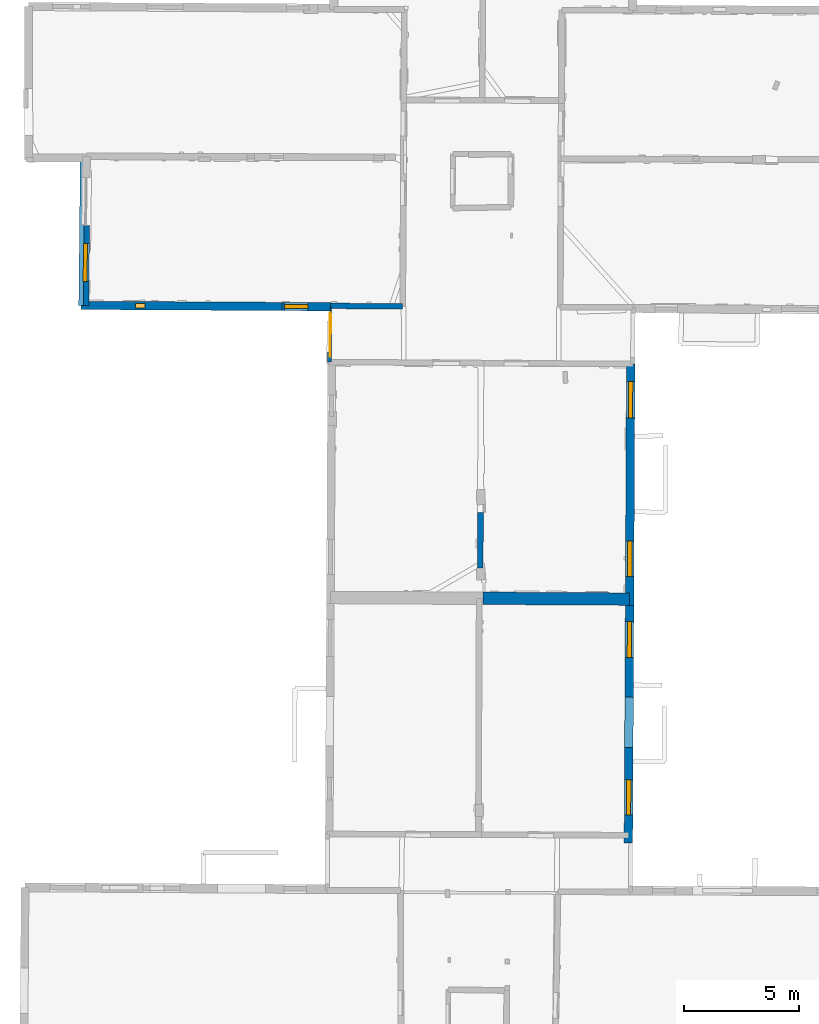
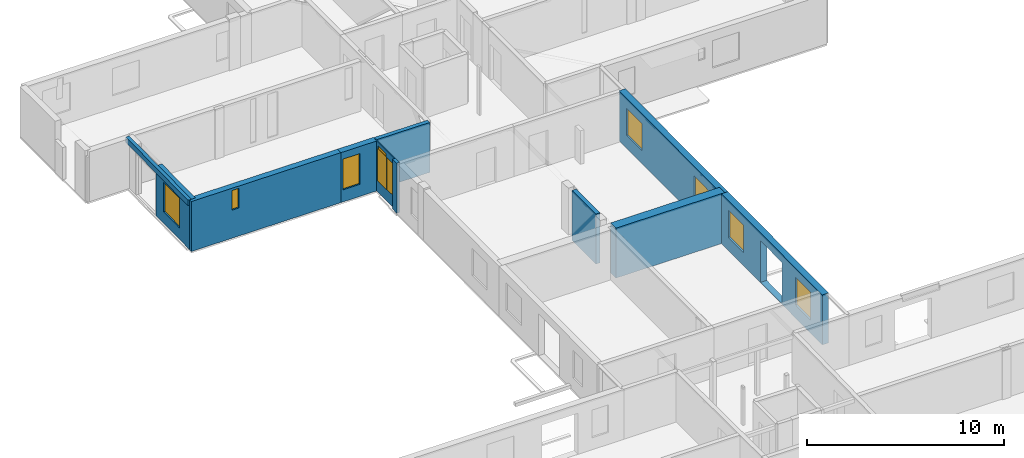
# One storey, part 8 of 17: 11 walls, 8 windows, 2 doors, 11 openings.
"""IFC2X3 building model written with IfcOpenShell, lengths in metres."""

from ifc_helpers import new_model, entity, si_unit, converted_unit, derived_unit, direction, frame, frame_2d, origin, origin_2d_with_axis, place, context, subcontext, project, spatial, polyline, rectangle, outline, extrude, clip, halfspace, source, transform, mapped, material, layer, layer_set, layer_usage, type_object, type_shapes, element, fill, save


model = new_model("IFC2X3")

# Units and contexts
model_context = context("Model", 3, precision=1e-05, world=origin(), true_north=direction((0.0, 1.0)))
body_context = subcontext(model_context, "Body", "Model", "MODEL_VIEW")
ifc_project = project(units=[si_unit("LENGTHUNIT", "METRE"), si_unit("AREAUNIT", "SQUARE_METRE"), si_unit("VOLUMEUNIT", "CUBIC_METRE"), converted_unit("PLANEANGLEUNIT", "DEGREE", entity("IfcRatioMeasure", 0.0174532925199433), si_unit("PLANEANGLEUNIT", "RADIAN"), dimensions=[0, 0, 0, 0, 0, 0, 0]), si_unit("MASSUNIT", "GRAM", prefix="KILO"), derived_unit("MASSDENSITYUNIT", [(si_unit("MASSUNIT", "GRAM", prefix="KILO"), 1), (si_unit("LENGTHUNIT", "METRE"), -3)]), derived_unit("MOMENTOFINERTIAUNIT", [(si_unit("LENGTHUNIT", "METRE"), 4)]), si_unit("TIMEUNIT", "SECOND"), si_unit("FREQUENCYUNIT", "HERTZ"), si_unit("THERMODYNAMICTEMPERATUREUNIT", "DEGREE_CELSIUS"), derived_unit("THERMALTRANSMITTANCEUNIT", [(si_unit("MASSUNIT", "GRAM", prefix="KILO"), 1), (si_unit("THERMODYNAMICTEMPERATUREUNIT", "KELVIN"), -1), (si_unit("TIMEUNIT", "SECOND"), -3)]), derived_unit("VOLUMETRICFLOWRATEUNIT", [(si_unit("LENGTHUNIT", "METRE"), 3), (si_unit("TIMEUNIT", "SECOND"), -1)]), si_unit("ELECTRICCURRENTUNIT", "AMPERE"), si_unit("ELECTRICVOLTAGEUNIT", "VOLT"), si_unit("POWERUNIT", "WATT"), si_unit("FORCEUNIT", "NEWTON", prefix="KILO"), si_unit("ILLUMINANCEUNIT", "LUX"), si_unit("LUMINOUSFLUXUNIT", "LUMEN"), si_unit("LUMINOUSINTENSITYUNIT", "CANDELA"), derived_unit("USERDEFINED", [(si_unit("MASSUNIT", "GRAM", prefix="KILO"), -1), (si_unit("LENGTHUNIT", "METRE"), -2), (si_unit("TIMEUNIT", "SECOND"), 3), (si_unit("LUMINOUSFLUXUNIT", "LUMEN"), 1)]), derived_unit("LINEARVELOCITYUNIT", [(si_unit("LENGTHUNIT", "METRE"), 1), (si_unit("TIMEUNIT", "SECOND"), -1)]), si_unit("PRESSUREUNIT", "PASCAL"), derived_unit("USERDEFINED", [(si_unit("LENGTHUNIT", "METRE"), -2), (si_unit("MASSUNIT", "GRAM", prefix="KILO"), 1), (si_unit("TIMEUNIT", "SECOND"), -2)]), derived_unit("LINEARFORCEUNIT", [(si_unit("MASSUNIT", "GRAM", prefix="KILO"), 1), (si_unit("LENGTHUNIT", "METRE"), 1), (si_unit("TIMEUNIT", "SECOND"), -2), (si_unit("LENGTHUNIT", "METRE"), -1)]), derived_unit("PLANARFORCEUNIT", [(si_unit("MASSUNIT", "GRAM", prefix="KILO"), 1), (si_unit("LENGTHUNIT", "METRE"), 1), (si_unit("TIMEUNIT", "SECOND"), -2), (si_unit("LENGTHUNIT", "METRE"), -2)])], contexts=[model_context])

# Site, building, storey
placement_1 = place(None, origin())
site = spatial("IfcSite", under=ifc_project, at=placement_1, CompositionType="ELEMENT")
building = spatial("IfcBuilding", under=site, at=placement_1, CompositionType="ELEMENT")
storey_placement = place(placement_1, frame((0.0, 0.0, 12.0782108306885)))
storey = spatial("IfcBuildingStorey", under=building, at=storey_placement, Name="Level 5", CompositionType="ELEMENT", Elevation=12.0782108306885)

# Walls
ifc_material_1 = material(Name="Default wall")
ifc_layer_1 = layer(ifc_material_1, 0.25)
ifc_layer_set_1 = layer_set([ifc_layer_1], Name="wall_thickness_0.2500")
ifc_layer_usage_1 = layer_usage(ifc_layer_set_1, "AXIS2", "POSITIVE", -0.125)
wall_type_1 = type_object("IfcWallType", Name="wall_thickness_0.2500", PredefinedType="STANDARD", material=ifc_layer_set_1)
wall_1_placement = place(storey_placement, frame((6.29722925485367, 42.283165791844, 0.0), z_axis=(0.0, 0.0, 1.0), x_axis=(-0.00286249476828842, -0.999995903053458, 0.0)))
element("IfcWallStandardCase", 1, at=wall_1_placement, inside=storey, type_object=wall_type_1, material=ifc_layer_usage_1, Name="Wall:283", ObjectType="Wall", context=body_context, shape_type="Clipping", body=[
    clip(extrude(outline(polyline([(2.41509091866831, -0.125), (2.41509091866831, 0.125), (0.0, 0.125), (0.0, -0.125), (2.41509091866831, -0.125)])), origin(), (0.0, 0.0, 1.0), 3.09134044647217), halfspace(frame((-34.9719704962711, 6.41921446735777, 6.35864093399329), z_axis=(0.00078599974921783, 0.390499331703028, 0.920602875372374), x_axis=(0.672212265497476, -0.68178244229521, 0.288623234499112)), False)),
])
ifc_layer_2 = layer(ifc_material_1, 0.239999994635582)
ifc_layer_set_2 = layer_set([ifc_layer_2], Name="wall_thickness_0.2400")
ifc_layer_usage_2 = layer_usage(ifc_layer_set_2, "AXIS2", "POSITIVE", -0.119999997317791)
wall_type_2 = type_object("IfcWallType", Name="wall_thickness_0.2400", PredefinedType="STANDARD", material=ifc_layer_set_2)
wall_2_placement = place(storey_placement, frame((-0.197353885581661, 51.2372060309085, 0.0), z_axis=(0.0, 0.0, 1.0), x_axis=(0.999963710413645, -0.00851926380478781, 0.0)))
element("IfcWallStandardCase", 2, at=wall_2_placement, inside=storey, type_object=wall_type_2, material=ifc_layer_usage_2, Name="Wall:308", ObjectType="Wall", context=body_context, shape_type="Clipping", body=[
    clip(clip(extrude(outline(polyline([(3.1218741367054, -0.119999997317791), (3.1218741367054, 0.119999997317791), (0.0, 0.119999997317791), (0.0, -0.119999997317791), (3.1218741367054, -0.119999997317791)])), origin(), (0.0, 0.0, 1.0), 3.09134044647217), halfspace(frame((-12.6113322335833, 6.46281732421006, 9.01748660239985), z_axis=(-0.000555902110739086, -0.391129360163984, 0.920335544565435), x_axis=(0.999999642265209, 0.00036931091099487, 0.000760972341273259)), False)), halfspace(frame((-1.2750383568859, 24.5966275881706, 5.79573318480268), z_axis=(-0.389896108881806, -0.00190726739364772, 0.920856876289642), x_axis=(0.92085314643809, 0.00229807623882634, 0.389902810378011)), False)),
])

# Wall, opening, window
ifc_layer_3 = layer(ifc_material_1, 0.340000003576279)
ifc_layer_set_3 = layer_set([ifc_layer_3], Name="wall_thickness_0.3400")
ifc_layer_usage_3 = layer_usage(ifc_layer_set_3, "AXIS2", "POSITIVE", -0.170000001788139)
wall_type_3 = type_object("IfcWallType", Name="wall_thickness_0.3400", PredefinedType="STANDARD", material=ifc_layer_set_3)
wall_3_placement = place(storey_placement, frame((-10.8299699724623, 54.7178954017994, 0.0), z_axis=(0.0, 0.0, 1.0), x_axis=(-0.00854984939122819, -0.999963449369719, 0.0)))
wall_3 = element("IfcWallStandardCase", 3, at=wall_3_placement, inside=storey, type_object=wall_type_3, material=ifc_layer_usage_3, Name="Wall:355", ObjectType="Wall", context=body_context, shape_type="Clipping", body=[
    clip(extrude(outline(polyline([(3.46128526459941, -0.170000001788139), (3.46128526459941, 0.170000001788139), (0.0, 0.170000001788139), (0.0, -0.170000001788139), (3.46128526459941, -0.170000001788139)])), origin(), (0.0, 0.0, 1.0), 3.09134044647217), halfspace(frame((-3.07277669882318, -1.94954307598141, 9.01748660239985), z_axis=(0.391129376984236, -0.000543938753920477, 0.920335544565435), x_axis=(-0.000399897600284288, 0.999999630501434, 0.000760972341273259)), False)),
])
opening_1_placement = place(wall_3_placement, frame((0.769696676994502, -0.170000001788139, 0.705789566040039)))
opening_1 = element("IfcOpeningElement", 4, at=opening_1_placement, cuts=wall_3, Name="Opening : 1645 x 1830 : 294", ObjectType="Opening", context=body_context, shape_type="SweptSolid", body=[
    extrude(rectangle(XDim=1.645, YDim=1.83, at=frame_2d((0.915, 0.8225), x_axis=(0.0, 1.0))), frame((0.0, 0.0, 0.0), z_axis=(0.0, 1.0, 0.0), x_axis=(0.0, 0.0, 1.0)), (0.0, 0.0, 1.0), 0.340000003576279),
])
ifc_material_2 = material(Name="Window Default")
window_style_1 = type_object("IfcWindowStyle", Name="Window : 1645 x 1830mm", ConstructionType="NOTDEFINED", OperationType="NOTDEFINED", ParameterTakesPrecedence=False, Sizeable=False, material=ifc_material_2)
shared_shape_1 = source(origin(), body_context, "Body", "SweptSolid", [
    extrude(rectangle(XDim=0.170000001788139, YDim=1.645, at=origin_2d_with_axis()), frame((0.8225, 0.170000001788139, 0.0), z_axis=(0.0, 0.0, 1.0), x_axis=(0.0, 1.0, 0.0)), (0.0, 0.0, 1.0), 1.83),
])
type_shapes(window_style_1, [shared_shape_1])
window_1_placement = place(opening_1_placement, origin())
window_1 = element("IfcWindow", 5, at=window_1_placement, inside=storey, type_object=window_style_1, Name="Window : 1645 x 1830mm : 161", ObjectType="Window : 1645 x 1830mm", OverallHeight=1.83, OverallWidth=1.645, context=body_context, shape_type="MappedRepresentation", body=[
    mapped(shared_shape_1, transform((0.0, 0.0, 0.0), scale=1.0)),
])
fill(opening_1, window_1)

# Wall, openings, windows
ifc_layer_4 = layer(ifc_material_1, 0.370000004768372)
ifc_layer_set_4 = layer_set([ifc_layer_4], Name="wall_thickness_0.3700")
ifc_layer_usage_4 = layer_usage(ifc_layer_set_4, "AXIS2", "POSITIVE", -0.185000002384186)
wall_type_4 = type_object("IfcWallType", Name="wall_thickness_0.3700", PredefinedType="STANDARD", material=ifc_layer_set_4)
wall_4_placement = place(storey_placement, frame((12.8162219420106, 48.7182321121233, 0.0), z_axis=(0.0, 0.0, 1.0), x_axis=(-0.00487136037123497, -0.999988134853676, 0.0)))
wall_4 = element("IfcWallStandardCase", 6, at=wall_4_placement, inside=storey, type_object=wall_type_4, material=ifc_layer_usage_4, Name="Wall:319", ObjectType="Wall", context=body_context, shape_type="Clipping", body=[
    clip(extrude(outline(polyline([(10.4694769440438, -0.185000002384186), (10.4694769440438, 0.185000002384186), (0.0, 0.185000002384186), (0.0, -0.185000002384186), (10.4694769440438, -0.185000002384186)])), origin(), (0.0, 0.0, 1.0), 3.09134044647217), halfspace(frame((-28.5180490289432, -0.138620775055655, 6.35864093399329), z_axis=(1.53201837703432e-06, 0.390500122732081, 0.920602875372374), x_axis=(0.673580527953323, -0.680430673080949, 0.288623234499112)), False)),
])
opening_2_placement = place(wall_4_placement, frame((0.770776334560423, -0.185000002384186, 0.800789833068848)))
opening_2 = element("IfcOpeningElement", 7, at=opening_2_placement, cuts=wall_4, Name="Opening : 1575 x 1680 : 260", ObjectType="Opening", context=body_context, shape_type="SweptSolid", body=[
    extrude(rectangle(XDim=1.575, YDim=1.68, at=frame_2d((0.84, 0.7875), x_axis=(0.0, 1.0))), frame((0.0, 0.0, 0.0), z_axis=(0.0, 1.0, 0.0), x_axis=(0.0, 0.0, 1.0)), (0.0, 0.0, 1.0), 0.370000004768372),
])
opening_3_placement = place(wall_4_placement, frame((7.67077580595639, -0.185000002384186, 0.800789833068848)))
opening_3 = element("IfcOpeningElement", 8, at=opening_3_placement, cuts=wall_4, Name="Opening : 1540 x 1680 : 261", ObjectType="Opening", context=body_context, shape_type="SweptSolid", body=[
    extrude(rectangle(XDim=1.54, YDim=1.68, at=frame_2d((0.84, 0.77), x_axis=(0.0, 1.0))), frame((0.0, 0.0, 0.0), z_axis=(0.0, 1.0, 0.0), x_axis=(0.0, 0.0, 1.0)), (0.0, 0.0, 1.0), 0.370000004768372),
])
window_style_2 = type_object("IfcWindowStyle", Name="Window : 1575 x 1680mm", ConstructionType="NOTDEFINED", OperationType="NOTDEFINED", ParameterTakesPrecedence=False, Sizeable=False, material=ifc_material_2)
shared_shape_2 = source(origin(), body_context, "Body", "SweptSolid", [
    extrude(rectangle(XDim=0.185000002384186, YDim=1.575, at=origin_2d_with_axis()), frame((0.7875, 0.185000002384186, 0.0), z_axis=(0.0, 0.0, 1.0), x_axis=(0.0, 1.0, 0.0)), (0.0, 0.0, 1.0), 1.68),
])
type_shapes(window_style_2, [shared_shape_2])
window_2_placement = place(opening_2_placement, origin())
window_2 = element("IfcWindow", 9, at=window_2_placement, inside=storey, type_object=window_style_2, Name="Window : 1575 x 1680mm : 140", ObjectType="Window : 1575 x 1680mm", OverallHeight=1.68, OverallWidth=1.575, context=body_context, shape_type="MappedRepresentation", body=[
    mapped(shared_shape_2, transform((0.0, 0.0, 0.0), scale=1.0)),
])
fill(opening_2, window_2)
window_style_3 = type_object("IfcWindowStyle", Name="Window : 1540 x 1680mm", ConstructionType="NOTDEFINED", OperationType="NOTDEFINED", ParameterTakesPrecedence=False, Sizeable=False, material=ifc_material_2)
shared_shape_3 = source(origin(), body_context, "Body", "SweptSolid", [
    extrude(rectangle(XDim=0.185000002384186, YDim=1.54, at=origin_2d_with_axis()), frame((0.77, 0.185000002384186, 0.0), z_axis=(0.0, 0.0, 1.0), x_axis=(0.0, 1.0, 0.0)), (0.0, 0.0, 1.0), 1.68),
])
type_shapes(window_style_3, [shared_shape_3])
window_3_placement = place(opening_3_placement, origin())
window_3 = element("IfcWindow", 10, at=window_3_placement, inside=storey, type_object=window_style_3, Name="Window : 1540 x 1680mm : 141", ObjectType="Window : 1540 x 1680mm", OverallHeight=1.68, OverallWidth=1.54, context=body_context, shape_type="MappedRepresentation", body=[
    mapped(shared_shape_3, transform((0.0, 0.0, 0.0), scale=1.0)),
])
fill(opening_3, window_3)

wall_5_placement = place(storey_placement, frame((12.7652213469178, 38.2488793899553, 0.0), z_axis=(0.0, 0.0, 1.0), x_axis=(-0.0048714299330896, -0.999988134514809, 0.0)))
wall_5 = element("IfcWallStandardCase", 11, at=wall_5_placement, inside=storey, type_object=wall_type_4, material=ifc_layer_usage_4, Name="Wall:320", ObjectType="Wall", context=body_context, shape_type="Clipping", body=[
    clip(extrude(outline(polyline([(10.3025323702777, -0.185000002384186), (10.3025323702777, 0.185000002384186), (0.0, 0.185000002384186), (0.0, -0.185000002384186), (10.3025323702777, -0.185000002384186)])), origin(), (0.0, 0.0, 1.0), 3.09134044647217), halfspace(frame((-38.9875259633442, -0.138623487132451, 6.35864093399329), z_axis=(1.50485414193323e-06, 0.390500122732186, 0.920602875372374), x_axis=(0.673580575285903, -0.68043062622488, 0.288623234499112)), False)),
])
opening_4_placement = place(wall_5_placement, frame((3.98729092686499, -0.185000002384186, 0.0277891159057617)))
element("IfcOpeningElement", 12, at=opening_4_placement, cuts=wall_5, Name="Opening : 2175 x 2565 : 262", ObjectType="Opening", context=body_context, shape_type="SweptSolid", body=[
    extrude(rectangle(XDim=2.175, YDim=2.565, at=frame_2d((1.2825, 1.0875), x_axis=(0.0, 1.0))), frame((0.0, 0.0, 0.0), z_axis=(0.0, 1.0, 0.0), x_axis=(0.0, 0.0, 1.0)), (0.0, 0.0, 1.0), 0.370000004768372),
])
opening_5_placement = place(wall_5_placement, frame((0.696301105260744, -0.185000002384186, 0.815789222717285)))
opening_5 = element("IfcOpeningElement", 13, at=opening_5_placement, cuts=wall_5, Name="Opening : 1560 x 1695 : 263", ObjectType="Opening", context=body_context, shape_type="SweptSolid", body=[
    extrude(rectangle(XDim=1.56, YDim=1.695, at=frame_2d((0.8475, 0.78), x_axis=(0.0, 1.0))), frame((0.0, 0.0, 0.0), z_axis=(0.0, 1.0, 0.0), x_axis=(0.0, 0.0, 1.0)), (0.0, 0.0, 1.0), 0.370000004768372),
])
opening_6_placement = place(wall_5_placement, frame((7.56630144250896, -0.185000002384186, 0.805789947509766)))
opening_6 = element("IfcOpeningElement", 14, at=opening_6_placement, cuts=wall_5, Name="Opening : 1535 x 1720 : 264", ObjectType="Opening", context=body_context, shape_type="SweptSolid", body=[
    extrude(rectangle(XDim=1.535, YDim=1.72, at=frame_2d((0.86, 0.7675), x_axis=(0.0, 1.0))), frame((0.0, 0.0, 0.0), z_axis=(0.0, 1.0, 0.0), x_axis=(0.0, 0.0, 1.0)), (0.0, 0.0, 1.0), 0.370000004768372),
])
window_style_4 = type_object("IfcWindowStyle", Name="Window : 1560 x 1695mm", ConstructionType="NOTDEFINED", OperationType="NOTDEFINED", ParameterTakesPrecedence=False, Sizeable=False, material=ifc_material_2)
shared_shape_4 = source(origin(), body_context, "Body", "SweptSolid", [
    extrude(rectangle(XDim=0.185000002384186, YDim=1.56, at=origin_2d_with_axis()), frame((0.78, 0.185000002384186, 0.0), z_axis=(0.0, 0.0, 1.0), x_axis=(0.0, 1.0, 0.0)), (0.0, 0.0, 1.0), 1.695),
])
type_shapes(window_style_4, [shared_shape_4])
window_4_placement = place(opening_5_placement, origin())
window_4 = element("IfcWindow", 15, at=window_4_placement, inside=storey, type_object=window_style_4, Name="Window : 1560 x 1695mm : 142", ObjectType="Window : 1560 x 1695mm", OverallHeight=1.695, OverallWidth=1.56, context=body_context, shape_type="MappedRepresentation", body=[
    mapped(shared_shape_4, transform((0.0, 0.0, 0.0), scale=1.0)),
])
fill(opening_5, window_4)
window_style_5 = type_object("IfcWindowStyle", Name="Window : 1535 x 1720mm", ConstructionType="NOTDEFINED", OperationType="NOTDEFINED", ParameterTakesPrecedence=False, Sizeable=False, material=ifc_material_2)
shared_shape_5 = source(origin(), body_context, "Body", "SweptSolid", [
    extrude(rectangle(XDim=0.185000002384186, YDim=1.535, at=origin_2d_with_axis()), frame((0.7675, 0.185000002384186, 0.0), z_axis=(0.0, 0.0, 1.0), x_axis=(0.0, 1.0, 0.0)), (0.0, 0.0, 1.0), 1.72),
])
type_shapes(window_style_5, [shared_shape_5])
window_5_placement = place(opening_6_placement, origin())
window_5 = element("IfcWindow", 16, at=window_5_placement, inside=storey, type_object=window_style_5, Name="Window : 1535 x 1720mm : 143", ObjectType="Window : 1535 x 1720mm", OverallHeight=1.72, OverallWidth=1.535, context=body_context, shape_type="MappedRepresentation", body=[
    mapped(shared_shape_5, transform((0.0, 0.0, 0.0), scale=1.0)),
])
fill(opening_6, window_5)

# Wall
ifc_layer_5 = layer(ifc_material_1, 0.200000002980232)
ifc_layer_set_5 = layer_set([ifc_layer_5], Name="wall_thickness_0.2000")
ifc_layer_usage_5 = layer_usage(ifc_layer_set_5, "AXIS2", "POSITIVE", -0.100000001490116)
wall_type_5 = type_object("IfcWallType", Name="wall_thickness_0.2000", PredefinedType="STANDARD", material=ifc_layer_set_5)
placement_2 = place(placement_1, frame((0.0, 0.0, 14.8339996337891)))
wall_6_placement = place(placement_2, frame((-10.9594779425102, 57.6862403643536, 0.0), z_axis=(0.0, 0.0, 1.0), x_axis=(-0.0107495036454466, -0.999942222416564, 0.0)))
element("IfcWallStandardCase", 17, at=wall_6_placement, inside=storey, type_object=wall_type_5, material=ifc_layer_usage_5, Name="Wall:258", ObjectType="Wall", context=body_context, shape_type="Clipping", body=[
    clip(extrude(outline(polyline([(6.42894887222558, -0.100000001490116), (6.42894887222558, 0.100000001490116), (0.0, 0.100000001490116), (0.0, -0.100000001490116), (6.42894887222558, -0.100000001490116)])), origin(), (0.0, 0.0, 1.0), 0.335551643371582), halfspace(frame((-0.101699434191863, -1.79488899370468, 6.26169779929927), z_axis=(0.391129627192691, 0.000316451498836618, 0.920335544565435), x_axis=(-0.00259965116266138, 0.999996331360735, 0.000760972341273259)), False)),
])

# Wall, opening, window
ifc_layer_6 = layer(ifc_material_1, 0.360000014305115)
ifc_layer_set_6 = layer_set([ifc_layer_6], Name="wall_thickness_0.3600")
ifc_layer_usage_6 = layer_usage(ifc_layer_set_6, "AXIS2", "POSITIVE", -0.180000007152557)
wall_type_6 = type_object("IfcWallType", Name="wall_thickness_0.3600", PredefinedType="STANDARD", material=ifc_layer_set_6)
wall_7_placement = place(storey_placement, frame((-11.0285872309145, 51.2576645103254, 0.0), z_axis=(0.0, 0.0, 1.0), x_axis=(0.999984809669688, -0.00551184450778611, 0.0)))
wall_7 = element("IfcWallStandardCase", 18, at=wall_7_placement, inside=storey, type_object=wall_type_6, material=ifc_layer_usage_6, Name="Wall:275", ObjectType="Wall", context=body_context, shape_type="Clipping", body=[
    clip(extrude(outline(polyline([(8.72103706413301, -0.180000007152557), (8.72103706413301, 0.180000007152557), (0.0, 0.180000007152557), (0.0, -0.180000007152557), (8.72103706413301, -0.180000007152557)])), origin(), (0.0, 0.0, 1.0), 3.09134044647217), halfspace(frame((-1.76065676156725, 6.53995845588132, 9.01748660239985), z_axis=(-0.00173221720052411, -0.391125919408334, 0.920335544565435), x_axis=(0.999996230457662, -0.00263817959246063, 0.00076097234127326)), False)),
])
opening_7_placement = place(wall_7_placement, frame((2.36915201424665, -0.180000007152557, 1.73278903961182)))
opening_7 = element("IfcOpeningElement", 19, at=opening_7_placement, cuts=wall_7, Name="Opening : 405 x 1215 : 238", ObjectType="Opening", context=body_context, shape_type="SweptSolid", body=[
    extrude(rectangle(XDim=0.405, YDim=1.215, at=frame_2d((0.6075, 0.2025), x_axis=(0.0, 1.0))), frame((0.0, 0.0, 0.0), z_axis=(0.0, 1.0, 0.0), x_axis=(0.0, 0.0, 1.0)), (0.0, 0.0, 1.0), 0.360000014305115),
])
window_style_6 = type_object("IfcWindowStyle", Name="Window : 405 x 1215mm", ConstructionType="NOTDEFINED", OperationType="NOTDEFINED", ParameterTakesPrecedence=False, Sizeable=False, material=ifc_material_2)
shared_shape_6 = source(origin(), body_context, "Body", "SweptSolid", [
    extrude(rectangle(XDim=0.180000007152557, YDim=0.405, at=origin_2d_with_axis()), frame((0.2025, 0.180000007152557, 0.0), z_axis=(0.0, 0.0, 1.0), x_axis=(0.0, 1.0, 0.0)), (0.0, 0.0, 1.0), 1.215),
])
type_shapes(window_style_6, [shared_shape_6])
window_6_placement = place(opening_7_placement, origin())
window_6 = element("IfcWindow", 20, at=window_6_placement, inside=storey, type_object=window_style_6, Name="Window : 405 x 1215mm : 128", ObjectType="Window : 405 x 1215mm", OverallHeight=1.215, OverallWidth=0.405, context=body_context, shape_type="MappedRepresentation", body=[
    mapped(shared_shape_6, transform((0.0, 0.0, 0.0), scale=1.0)),
])
fill(opening_7, window_6)

wall_8_placement = place(storey_placement, frame((-2.30768264221512, 51.2095955100813, 0.0), z_axis=(0.0, 0.0, 1.0), x_axis=(0.999984812284197, -0.00551137015082637, 0.0)))
wall_8 = element("IfcWallStandardCase", 21, at=wall_8_placement, inside=storey, type_object=wall_type_6, material=ifc_layer_usage_6, Name="Wall:276", ObjectType="Wall", context=body_context, shape_type="Clipping", body=[
    clip(clip(extrude(outline(polyline([(2.11036668643036, -0.180000007152557), (2.11036668643036, 0.180000007152557), (0.0, 0.180000007152557), (0.0, -0.180000007152557), (2.11036668643036, -0.180000007152557)])), origin(), (0.0, 0.0, 1.0), 3.09134044647217), halfspace(frame((-10.4816907233771, 6.53996342802052, 9.01748660239985), z_axis=(-0.00173240273664403, -0.391125918586588, 0.920335544565435), x_axis=(0.999996229206092, -0.00263865395483708, 0.000760972341273259)), False)), halfspace(frame((0.909097722040085, 24.6395924888581, 5.79573318480268), z_axis=(-0.389900082009421, -0.000734465200318769, 0.920856876289642), x_axis=(0.920855893089749, -0.000471827520979405, 0.389902810378011)), False)),
])
opening_8_placement = place(wall_8_placement, frame((0.111095074304878, -0.180000007152557, 0.750789642333984)))
opening_8 = element("IfcOpeningElement", 22, at=opening_8_placement, cuts=wall_8, Name="Opening : 1005 x 1900 : 239", ObjectType="Opening", context=body_context, shape_type="SweptSolid", body=[
    extrude(rectangle(XDim=1.005, YDim=1.9, at=frame_2d((0.95, 0.5025), x_axis=(0.0, 1.0))), frame((0.0, 0.0, 0.0), z_axis=(0.0, 1.0, 0.0), x_axis=(0.0, 0.0, 1.0)), (0.0, 0.0, 1.0), 0.360000014305115),
])
window_style_7 = type_object("IfcWindowStyle", Name="Window : 1005 x 1900mm", ConstructionType="NOTDEFINED", OperationType="NOTDEFINED", ParameterTakesPrecedence=False, Sizeable=False, material=ifc_material_2)
shared_shape_7 = source(origin(), body_context, "Body", "SweptSolid", [
    extrude(rectangle(XDim=0.180000007152557, YDim=1.005, at=origin_2d_with_axis()), frame((0.5025, 0.180000007152557, 0.0), z_axis=(0.0, 0.0, 1.0), x_axis=(0.0, 1.0, 0.0)), (0.0, 0.0, 1.0), 1.9),
])
type_shapes(window_style_7, [shared_shape_7])
window_7_placement = place(opening_8_placement, origin())
window_7 = element("IfcWindow", 23, at=window_7_placement, inside=storey, type_object=window_style_7, Name="Window : 1005 x 1900mm : 129", ObjectType="Window : 1005 x 1900mm", OverallHeight=1.9, OverallWidth=1.005, context=body_context, shape_type="MappedRepresentation", body=[
    mapped(shared_shape_7, transform((0.0, 0.0, 0.0), scale=1.0)),
])
fill(opening_8, window_7)

# Walls
ifc_layer_7 = layer(ifc_material_1, 0.170000001788139)
ifc_layer_set_7 = layer_set([ifc_layer_7], Name="wall_thickness_0.1700")
ifc_layer_usage_7 = layer_usage(ifc_layer_set_7, "AXIS2", "POSITIVE", -0.0850000008940697)
wall_type_7 = type_object("IfcWallType", Name="wall_thickness_0.1700", PredefinedType="STANDARD", material=ifc_layer_set_7)
wall_9_placement = place(storey_placement, frame((-0.242380347011896, 49.2389794954016, 0.0), z_axis=(0.0, 0.0, 1.0), x_axis=(-0.0052041412738225, -0.999986458365113, 0.0)))
element("IfcWallStandardCase", 24, at=wall_9_placement, inside=storey, type_object=wall_type_7, material=ifc_layer_usage_7, Name="Wall:336", ObjectType="Wall", context=body_context, shape_type="Clipping", body=[
    clip(extrude(outline(polyline([(0.441084159035792, -0.0850000008940697), (0.441084159035792, 0.0850000008940697), (0.0, 0.0850000008940697), (0.0, -0.0850000008940697), (0.441084159035792, -0.0850000008940697)])), origin(), (0.0, 0.0, 1.0), 3.09134044647217), halfspace(frame((-26.5991532252862, -1.15886190974267, 5.79573318480268), z_axis=(0.000614674883393667, -0.389900289259794, 0.920856876289642), x_axis=(0.000754745077971345, 0.920855704667782, 0.389902810378011)), False)),
])
ifc_layer_8 = layer(ifc_material_1, 0.540000021457672)
ifc_layer_set_8 = layer_set([ifc_layer_8], Name="wall_thickness_0.5400")
ifc_layer_usage_8 = layer_usage(ifc_layer_set_8, "AXIS2", "POSITIVE", -0.270000010728836)
wall_type_8 = type_object("IfcWallType", Name="wall_thickness_0.5400", PredefinedType="STANDARD", material=ifc_layer_set_8)
wall_10_placement = place(storey_placement, frame((6.41446409768811, 38.5528673907683, 0.0), z_axis=(0.0, 0.0, 1.0), x_axis=(0.99998568132182, -0.00535136910848298, 0.0)))
element("IfcWallStandardCase", 25, at=wall_10_placement, inside=storey, type_object=wall_type_8, material=ifc_layer_usage_8, Name="Wall:265", ObjectType="Wall", context=body_context, shape_type="Clipping", body=[
    clip(extrude(outline(polyline([(6.35216271665865, -0.270000010728836), (6.35216271665865, 0.270000010728836), (0.0, 0.270000010728836), (0.0, -0.270000010728836), (6.35216271665865, -0.270000010728836)])), origin(), (0.0, 0.0, 1.0), 3.09134044647217), halfspace(frame((6.19495771064924, 38.7174565393451, 6.35864093399329), z_axis=(0.390500078479045, 0.000185913895835305, 0.920602875372374), x_axis=(-0.680107265937409, -0.673907067277391, 0.288623234499112)), False)),
])

# Wall, openings, doors, window
ifc_layer_9 = layer(ifc_material_1, 0.0700000002980232)
ifc_layer_set_9 = layer_set([ifc_layer_9], Name="wall_thickness_0.0700")
ifc_layer_usage_9 = layer_usage(ifc_layer_set_9, "AXIS2", "POSITIVE", -0.0350000001490116)
wall_type_9 = type_object("IfcWallType", Name="wall_thickness_0.0700", PredefinedType="STANDARD", material=ifc_layer_set_9)
wall_11_placement = place(storey_placement, frame((-0.197119299081503, 49.2394368118205, 0.0), z_axis=(0.0, 0.0, 1.0), x_axis=(-0.000117320797531557, 0.999999993117915, 0.0)))
wall_11 = element("IfcWallStandardCase", 26, at=wall_11_placement, inside=storey, type_object=wall_type_9, material=ifc_layer_usage_9, Name="Wall:239", ObjectType="Wall", context=body_context, shape_type="Clipping", body=[
    clip(clip(extrude(outline(polyline([(1.95852662480687, -0.0350000001490116), (1.95852662480687, 0.0350000001490116), (0.0, 0.0350000001490116), (0.0, -0.0350000001490116), (1.95852662480687, -0.0350000001490116)])), origin(), (0.0, 0.0, 1.0), 3.09134044647217), halfspace(frame((8.56926430347783, 12.5550454478288, 9.01748660239985), z_axis=(-0.391109971527753, 0.00393390149917188, 0.920335544565435), x_axis=(-0.00826728005936879, -0.999965535906871, 0.000760972341273259)), False)), halfspace(frame((26.6044914374528, 1.06256026079902, 5.79573318480268), z_axis=(0.00146017278733255, 0.389898039602041, 0.920856876289642), x_axis=(-0.00565503160110168, -0.920838649860506, 0.389902810378011)), False)),
])
opening_9_placement = place(wall_11_placement, frame((-0.199943543937523, -0.0350000001490116, 0.732789039611816)))
opening_9 = element("IfcOpeningElement", 27, at=opening_9_placement, cuts=wall_11, Name="Opening : 930 x 1960 : 215", ObjectType="Opening", context=body_context, shape_type="SweptSolid", body=[
    extrude(rectangle(XDim=0.93, YDim=1.96, at=frame_2d((0.98, 0.465), x_axis=(0.0, 1.0))), frame((0.0, 0.0, 0.0), z_axis=(0.0, 1.0, 0.0), x_axis=(0.0, 0.0, 1.0)), (0.0, 0.0, 1.0), 0.0700000002980232),
])
opening_10_placement = place(wall_11_placement, frame((0.750057225538853, -0.0350000001490116, 0.697789192199707)))
opening_10 = element("IfcOpeningElement", 28, at=opening_10_placement, cuts=wall_11, Name="Opening : 950 x 1995 : 216", ObjectType="Opening", context=body_context, shape_type="SweptSolid", body=[
    extrude(rectangle(XDim=0.95, YDim=1.995, at=frame_2d((0.9975, 0.475), x_axis=(0.0, 1.0))), frame((0.0, 0.0, 0.0), z_axis=(0.0, 1.0, 0.0), x_axis=(0.0, 0.0, 1.0)), (0.0, 0.0, 1.0), 0.0700000002980232),
])
opening_11_placement = place(wall_11_placement, frame((0.816055303386299, -0.0350000001490116, 2.01878929138184)))
opening_11 = element("IfcOpeningElement", 29, at=opening_11_placement, cuts=wall_11, Name="Opening : 810 x 865 : 217", ObjectType="Opening", context=body_context, shape_type="SweptSolid", body=[
    extrude(rectangle(XDim=0.81, YDim=0.865, at=frame_2d((0.4325, 0.405), x_axis=(0.0, 1.0))), frame((0.0, 0.0, 0.0), z_axis=(0.0, 1.0, 0.0), x_axis=(0.0, 0.0, 1.0)), (0.0, 0.0, 1.0), 0.0700000002980232),
])
ifc_material_3 = material(Name="Door Panel")
door_style_1 = type_object("IfcDoorStyle", Name="Door : 930 x 1960mm", ConstructionType="NOTDEFINED", OperationType="SINGLE_SWING_RIGHT", ParameterTakesPrecedence=False, Sizeable=False, material=ifc_material_3)
shared_shape_8 = source(origin(), body_context, "Body", "SweptSolid", [
    extrude(rectangle(XDim=0.0175000000745058, YDim=0.93, at=origin_2d_with_axis()), frame((0.465, 0.0612500002607703, 0.0), z_axis=(0.0, 0.0, 1.0), x_axis=(0.0, 1.0, 0.0)), (0.0, 0.0, 1.0), 1.96),
])
type_shapes(door_style_1, [shared_shape_8])
door_1_placement = place(opening_9_placement, origin())
door_1 = element("IfcDoor", 30, at=door_1_placement, inside=storey, type_object=door_style_1, Name="Door : 930 x 1960mm : 36", ObjectType="Door : 930 x 1960mm", OverallHeight=1.96, OverallWidth=0.93, context=body_context, shape_type="MappedRepresentation", body=[
    mapped(shared_shape_8, transform((0.0, 0.0, 0.0), scale=1.0)),
])
fill(opening_9, door_1)
door_style_2 = type_object("IfcDoorStyle", Name="Door : 950 x 1995mm", ConstructionType="NOTDEFINED", OperationType="SINGLE_SWING_RIGHT", ParameterTakesPrecedence=False, Sizeable=False, material=ifc_material_3)
shared_shape_9 = source(origin(), body_context, "Body", "SweptSolid", [
    extrude(rectangle(XDim=0.0175000000745058, YDim=0.95, at=origin_2d_with_axis()), frame((0.475, 0.0612500002607703, 0.0), z_axis=(0.0, 0.0, 1.0), x_axis=(0.0, 1.0, 0.0)), (0.0, 0.0, 1.0), 1.995),
])
type_shapes(door_style_2, [shared_shape_9])
door_2_placement = place(opening_10_placement, origin())
door_2 = element("IfcDoor", 31, at=door_2_placement, inside=storey, type_object=door_style_2, Name="Door : 950 x 1995mm : 37", ObjectType="Door : 950 x 1995mm", OverallHeight=1.995, OverallWidth=0.95, context=body_context, shape_type="MappedRepresentation", body=[
    mapped(shared_shape_9, transform((0.0, 0.0, 0.0), scale=1.0)),
])
fill(opening_10, door_2)
window_style_8 = type_object("IfcWindowStyle", Name="Window : 810 x 865mm", ConstructionType="NOTDEFINED", OperationType="NOTDEFINED", ParameterTakesPrecedence=False, Sizeable=False, material=ifc_material_2)
shared_shape_10 = source(origin(), body_context, "Body", "SweptSolid", [
    extrude(rectangle(XDim=0.0350000001490116, YDim=0.81, at=origin_2d_with_axis()), frame((0.405, 0.0350000001490116, 0.0), z_axis=(0.0, 0.0, 1.0), x_axis=(0.0, 1.0, 0.0)), (0.0, 0.0, 1.0), 0.865),
])
type_shapes(window_style_8, [shared_shape_10])
window_8_placement = place(opening_11_placement, origin())
window_8 = element("IfcWindow", 32, at=window_8_placement, inside=storey, type_object=window_style_8, Name="Window : 810 x 865mm : 116", ObjectType="Window : 810 x 865mm", OverallHeight=0.865, OverallWidth=0.81, context=body_context, shape_type="MappedRepresentation", body=[
    mapped(shared_shape_10, transform((0.0, 0.0, 0.0), scale=1.0)),
])
fill(opening_11, window_8)

save(model, "model.ifc")
